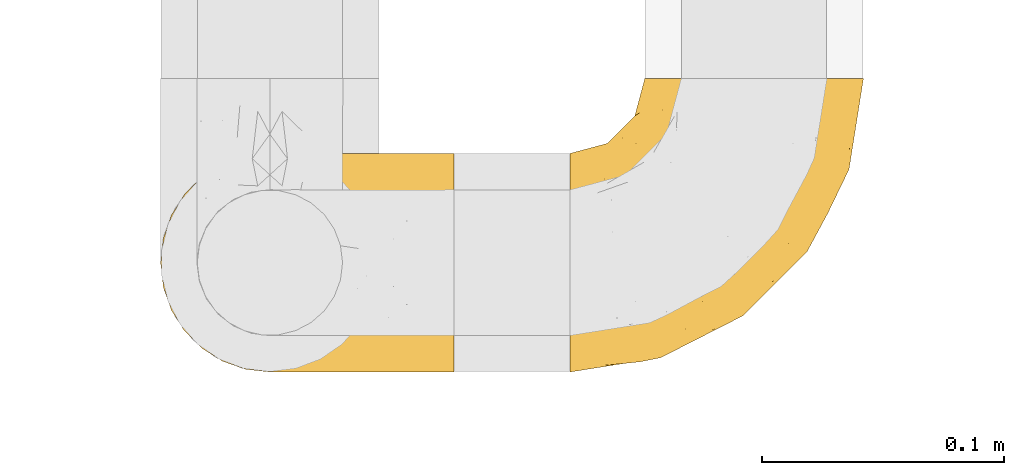
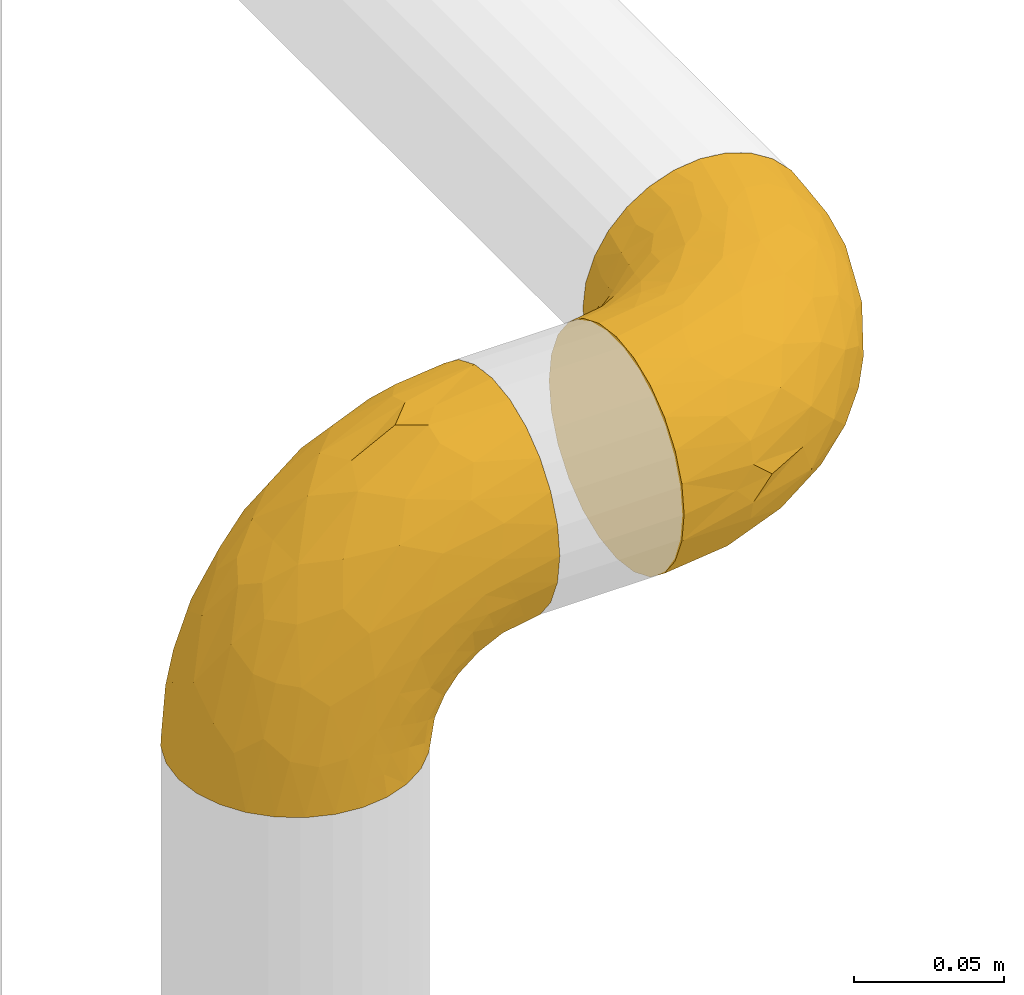
# One storey, part 107 of 827: 2 coverings.
"""IFC2X3 building model written with IfcOpenShell, lengths in millimetres."""

from ifc_helpers import new_model, entity, si_unit, converted_unit, derived_unit, direction, frame, origin, place, context, subcontext, project, spatial, faceted_brep, element, save


model = new_model("IFC2X3")

# Units and contexts
model_context = context("Model", 3, precision=0.01, world=origin(), true_north=direction((6.12303176911189e-17, 1.0)))
body_context = subcontext(model_context, "Body", "Model", "MODEL_VIEW")
ifc_project = project(units=[si_unit("LENGTHUNIT", "METRE", prefix="MILLI"), si_unit("AREAUNIT", "SQUARE_METRE"), si_unit("VOLUMEUNIT", "CUBIC_METRE"), converted_unit("PLANEANGLEUNIT", "DEGREE", entity("IfcRatioMeasure", 0.0174532925199433), si_unit("PLANEANGLEUNIT", "RADIAN"), dimensions=[0, 0, 0, 0, 0, 0, 0]), si_unit("MASSUNIT", "GRAM", prefix="KILO"), derived_unit("MASSDENSITYUNIT", [(si_unit("MASSUNIT", "GRAM", prefix="KILO"), 1), (si_unit("LENGTHUNIT", "METRE"), -3)]), derived_unit("MOMENTOFINERTIAUNIT", [(si_unit("LENGTHUNIT", "METRE"), 4)]), si_unit("TIMEUNIT", "SECOND"), si_unit("FREQUENCYUNIT", "HERTZ"), si_unit("THERMODYNAMICTEMPERATUREUNIT", "DEGREE_CELSIUS"), derived_unit("THERMALTRANSMITTANCEUNIT", [(si_unit("MASSUNIT", "GRAM", prefix="KILO"), 1), (si_unit("THERMODYNAMICTEMPERATUREUNIT", "KELVIN"), -1), (si_unit("TIMEUNIT", "SECOND"), -3)]), derived_unit("VOLUMETRICFLOWRATEUNIT", [(si_unit("LENGTHUNIT", "METRE"), 3), (si_unit("TIMEUNIT", "SECOND"), -1)]), derived_unit("MASSFLOWRATEUNIT", [(si_unit("MASSUNIT", "GRAM", prefix="KILO"), 1), (si_unit("TIMEUNIT", "SECOND"), -1)]), derived_unit("ROTATIONALFREQUENCYUNIT", [(si_unit("TIMEUNIT", "SECOND"), -1)]), si_unit("ELECTRICCURRENTUNIT", "AMPERE"), si_unit("ELECTRICVOLTAGEUNIT", "VOLT"), si_unit("POWERUNIT", "WATT"), si_unit("FORCEUNIT", "NEWTON", prefix="KILO"), si_unit("ILLUMINANCEUNIT", "LUX"), si_unit("LUMINOUSFLUXUNIT", "LUMEN"), si_unit("LUMINOUSINTENSITYUNIT", "CANDELA"), derived_unit("USERDEFINED", [(si_unit("MASSUNIT", "GRAM", prefix="KILO"), -1), (si_unit("LENGTHUNIT", "METRE"), -2), (si_unit("TIMEUNIT", "SECOND"), 3), (si_unit("LUMINOUSFLUXUNIT", "LUMEN"), 1)]), derived_unit("LINEARVELOCITYUNIT", [(si_unit("LENGTHUNIT", "METRE"), 1), (si_unit("TIMEUNIT", "SECOND"), -1)]), si_unit("PRESSUREUNIT", "PASCAL"), derived_unit("USERDEFINED", [(si_unit("LENGTHUNIT", "METRE"), -2), (si_unit("MASSUNIT", "GRAM", prefix="KILO"), 1), (si_unit("TIMEUNIT", "SECOND"), -2)]), derived_unit("LINEARFORCEUNIT", [(si_unit("MASSUNIT", "GRAM", prefix="KILO"), 1), (si_unit("LENGTHUNIT", "METRE"), 1), (si_unit("TIMEUNIT", "SECOND"), -2), (si_unit("LENGTHUNIT", "METRE"), -1)]), derived_unit("PLANARFORCEUNIT", [(si_unit("MASSUNIT", "GRAM", prefix="KILO"), 1), (si_unit("LENGTHUNIT", "METRE"), 1), (si_unit("TIMEUNIT", "SECOND"), -2), (si_unit("LENGTHUNIT", "METRE"), -2)])], contexts=[model_context])

# Site, building, storey
site_placement = place(None, origin())
site = spatial("IfcSite", under=ifc_project, at=site_placement, CompositionType="ELEMENT")
building_placement = place(site_placement, origin())
building = spatial("IfcBuilding", under=site, at=building_placement, CompositionType="ELEMENT")
storey_placement = place(building_placement, frame((0.0, 0.0, 28200.0)))
storey = spatial("IfcBuildingStorey", under=building, at=storey_placement, Name="08", CompositionType="ELEMENT", Elevation=28200.0)

# Coverings
covering_1_placement = place(storey_placement, frame((21222.65, 10451.58, 2353.25)))
element("IfcCovering", 1, at=covering_1_placement, inside=storey, Name=":ADSK_", ObjectType=":ADSK_", PredefinedType="INSULATION", context=body_context, shape_type="Brep", body=[
    faceted_brep([(87.65, 122.75, 90.76), (97.19, 122.75, 87.42), (105.75, 122.75, 82.04), (112.9, 122.75, 74.89), (118.28, 122.75, 66.33), (121.61, 122.75, 56.79), (122.75, 122.75, 46.75), (121.61, 122.75, 36.69), (118.27, 122.75, 27.15), (112.89, 122.75, 18.59), (105.74, 122.75, 11.44), (97.18, 122.75, 6.06), (87.64, 122.75, 2.73), (77.6, 122.75, 1.6), (67.54, 122.75, 2.73), (58.0, 122.75, 6.07), (49.44, 122.75, 11.45), (42.29, 122.75, 18.6), (36.91, 122.75, 27.16), (33.58, 122.75, 36.7), (32.45, 122.75, 46.75), (33.58, 122.75, 56.8), (36.92, 122.75, 66.34), (42.3, 122.75, 74.9), (49.45, 122.75, 82.05), (58.01, 122.75, 87.43), (67.55, 122.75, 90.76), (77.6, 122.75, 91.9), (1.6, 90.36, 35.06), (1.6, 85.85, 24.17), (1.6, 78.67, 14.82), (1.6, 69.32, 7.64), (1.6, 58.43, 3.13), (1.6, 46.75, 1.6), (1.6, 35.06, 3.13), (1.6, 24.17, 7.64), (1.6, 14.82, 14.82), (1.6, 7.64, 24.17), (1.6, 3.13, 35.06), (1.6, 1.6, 46.75), (1.6, 3.13, 58.43), (1.6, 7.64, 69.32), (1.6, 14.82, 78.67), (1.6, 24.17, 85.85), (1.6, 35.06, 90.36), (1.6, 46.75, 91.9), (1.6, 58.43, 90.36), (1.6, 69.32, 85.85), (1.6, 78.67, 78.67), (1.6, 85.85, 69.32), (1.6, 90.36, 58.43), (1.6, 91.9, 46.75), (99.61, 51.54, 46.75), (95.26, 47.17, 55.2), (86.21, 38.13, 46.75), (39.03, 7.52, 46.75), (30.75, 5.85, 54.53), (23.8, 5.11, 46.75), (60.8, 19.2, 59.63), (85.37, 38.98, 62.07), (73.64, 35.02, 71.86), (31.01, 8.21, 62.65), (49.14, 19.28, 71.33), (23.88, 12.19, 72.93), (82.74, 101.39, 91.2), (43.48, 34.43, 86.31), (29.47, 20.95, 80.89), (56.38, 30.74, 79.49), (72.18, 72.93, 90.68), (72.24, 56.64, 86.84), (87.6, 80.81, 87.38), (107.24, 93.43, 76.87), (101.1, 100.76, 83.73), (95.16, 74.27, 81.03), (71.81, 93.66, 91.9), (63.57, 81.33, 91.9), (55.34, 69.01, 91.9), (23.66, 40.87, 91.03), (20.55, 29.38, 87.58), (107.97, 67.05, 56.52), (116.82, 85.31, 46.75), (117.03, 93.68, 60.4), (30.68, 52.53, 91.9), (21.51, 50.71, 91.9), (12.33, 48.88, 91.9), (106.17, 72.77, 67.87), (52.37, 51.21, 90.35), (114.51, 101.18, 69.57), (119.23, 100.54, 46.75), (78.37, 48.74, 79.91), (75.46, 112.01, 91.9), (73.63, 102.83, 91.9), (101.51, 73.88, 74.99), (72.81, 24.73, 46.75), (43.01, 60.77, 91.9), (92.6, 103.08, 88.53), (91.86, 54.8, 72.65), (55.92, 16.13, 46.75), (99.01, 55.92, 62.97), (108.21, 68.42, 46.75), (32.05, 104.98, 66.2), (30.22, 108.58, 56.6), (23.37, 98.21, 59.89), (28.43, 61.56, 90.95), (16.44, 60.69, 90.22), (37.1, 100.0, 76.64), (28.88, 95.88, 71.58), (33.93, 90.81, 79.99), (50.17, 84.88, 89.54), (40.57, 73.29, 89.97), (47.62, 113.4, 81.32), (39.9, 109.8, 74.56), (47.92, 102.13, 84.15), (34.27, 67.29, 90.37), (24.65, 70.34, 87.82), (62.6, 95.15, 90.98), (66.18, 105.49, 90.96), (11.74, 71.5, 85.14), (13.89, 92.87, 58.11), (17.02, 96.03, 46.75), (15.86, 81.34, 78.39), (57.71, 107.44, 88.22), (9.11, 88.36, 66.06), (18.55, 90.43, 68.6), (34.74, 114.37, 63.78), (54.95, 98.41, 88.42), (57.35, 88.73, 90.61), (22.03, 76.89, 83.8), (24.8, 86.08, 77.98), (69.07, 112.64, 91.22), (42.31, 94.21, 83.46), (29.63, 112.22, 46.75), (28.31, 107.32, 46.75), (30.23, 79.95, 84.66), (40.13, 84.51, 86.33), (22.67, 101.67, 46.75), (12.12, 94.71, 46.75), (15.86, 81.34, 15.1), (22.03, 76.89, 9.69), (24.8, 86.08, 15.52), (30.23, 79.96, 8.83), (13.88, 92.87, 35.39), (47.61, 113.41, 12.18), (73.63, 102.83, 1.6), (66.17, 105.5, 2.53), (69.07, 112.64, 2.27), (30.22, 108.58, 36.9), (32.04, 104.98, 27.31), (23.36, 98.2, 33.62), (54.93, 98.4, 5.07), (47.91, 102.13, 9.36), (57.69, 107.44, 5.27), (9.1, 88.36, 27.43), (21.51, 50.71, 1.6), (12.33, 48.88, 1.6), (42.29, 94.22, 10.05), (37.09, 100.01, 16.87), (11.74, 71.5, 8.35), (16.44, 60.69, 3.27), (30.68, 52.53, 1.6), (28.86, 95.89, 21.94), (34.74, 114.37, 29.72), (63.57, 81.33, 1.6), (55.34, 69.01, 1.6), (50.17, 84.88, 3.96), (75.46, 112.01, 1.6), (39.89, 109.8, 18.95), (28.43, 61.56, 2.54), (34.27, 67.29, 3.12), (43.01, 60.77, 1.6), (62.59, 95.14, 2.51), (40.57, 73.29, 3.52), (40.13, 84.53, 7.17), (71.81, 93.66, 1.6), (33.92, 90.82, 13.52), (57.34, 88.73, 2.88), (24.65, 70.34, 5.67), (18.54, 90.43, 24.89), (29.47, 20.95, 12.6), (43.48, 34.43, 7.18), (56.4, 30.74, 14.0), (49.17, 19.29, 22.16), (73.69, 35.07, 21.61), (52.37, 51.21, 3.14), (72.26, 56.67, 6.65), (91.88, 54.85, 20.82), (85.36, 38.98, 31.41), (20.55, 29.38, 5.91), (23.66, 40.87, 2.46), (60.8, 19.2, 33.87), (31.02, 8.21, 30.84), (30.75, 5.85, 38.96), (23.9, 12.19, 20.56), (72.17, 72.93, 2.81), (87.59, 80.83, 6.1), (82.74, 101.39, 2.29), (117.03, 93.69, 33.08), (107.23, 93.43, 16.61), (107.97, 67.04, 36.96), (101.08, 100.76, 9.75), (106.17, 72.78, 25.61), (99.01, 55.93, 30.5), (114.5, 101.18, 23.91), (95.15, 74.27, 12.45), (101.5, 73.89, 18.49), (92.59, 103.09, 4.96), (78.38, 48.78, 13.56), (95.27, 47.19, 38.28)], [[[0, 1, 2, 3, 4, 5, 6, 7, 8, 9, 10, 11, 12, 13, 14, 15, 16, 17, 18, 19, 20, 21, 22, 23, 24, 25, 26, 27]], [[28, 29, 30, 31, 32, 33, 34, 35, 36, 37, 38, 39, 40, 41, 42, 43, 44, 45, 46, 47, 48, 49, 50, 51]], [[52, 53, 54]], [[55, 56, 57]], [[58, 59, 60]], [[61, 62, 63]], [[27, 64, 0]], [[65, 66, 67]], [[41, 40, 61]], [[68, 69, 70]], [[66, 43, 42]], [[63, 42, 41]], [[71, 72, 73]], [[72, 2, 1]], [[68, 74, 75, 76]], [[45, 44, 77]], [[43, 78, 44]], [[79, 80, 81]], [[77, 82, 83, 84, 45]], [[79, 81, 85]], [[71, 2, 72]], [[65, 86, 77]], [[4, 81, 5]], [[66, 65, 78]], [[4, 3, 87]], [[81, 88, 5]], [[63, 66, 42]], [[68, 70, 64]], [[67, 60, 89]], [[71, 3, 2]], [[64, 27, 90, 91, 74]], [[92, 71, 73]], [[40, 57, 56]], [[59, 93, 54]], [[86, 76, 94, 82]], [[1, 0, 95]], [[58, 62, 61]], [[60, 96, 89]], [[85, 81, 87]], [[56, 97, 58]], [[65, 67, 69]], [[87, 81, 4]], [[67, 89, 69]], [[61, 63, 41]], [[95, 72, 1]], [[73, 72, 70]], [[69, 73, 70]], [[73, 89, 96]], [[3, 71, 87]], [[85, 87, 71]], [[58, 61, 56]], [[59, 58, 93]], [[76, 86, 68]], [[69, 89, 73]], [[68, 86, 69]], [[65, 69, 86]], [[68, 64, 74]], [[95, 64, 70]], [[98, 79, 85]], [[79, 52, 99, 80]], [[66, 62, 67]], [[62, 58, 60]], [[62, 60, 67]], [[59, 98, 96]], [[59, 96, 60]], [[96, 85, 92]], [[88, 81, 80]], [[88, 6, 5]], [[66, 63, 62]], [[64, 95, 0]], [[72, 95, 70]], [[77, 44, 78]], [[86, 82, 77]], [[40, 39, 57]], [[96, 98, 85]], [[40, 56, 61]], [[66, 78, 43]], [[77, 78, 65]], [[79, 98, 53]], [[96, 92, 73]], [[85, 71, 92]], [[97, 56, 55]], [[97, 93, 58]], [[53, 98, 59]], [[54, 53, 59]], [[79, 53, 52]], [[100, 101, 102]], [[46, 45, 84, 83]], [[103, 104, 82]], [[82, 104, 83]], [[105, 106, 107]], [[108, 109, 76]], [[110, 111, 112]], [[103, 113, 114]], [[115, 74, 116]], [[48, 47, 117]], [[118, 102, 119]], [[49, 48, 120]], [[74, 91, 116]], [[116, 121, 115]], [[49, 122, 50]], [[123, 106, 102]], [[124, 111, 22]], [[125, 126, 115]], [[23, 22, 111]], [[24, 110, 121]], [[120, 127, 128]], [[90, 26, 129]], [[27, 26, 90]], [[121, 125, 115]], [[24, 121, 25]], [[130, 105, 107]], [[129, 25, 116]], [[21, 20, 131]], [[120, 123, 122]], [[112, 105, 130]], [[50, 118, 51]], [[21, 124, 22]], [[101, 131, 132]], [[117, 120, 48]], [[24, 23, 110]], [[127, 114, 133]], [[75, 108, 76]], [[107, 134, 130]], [[133, 114, 113]], [[129, 116, 91]], [[25, 121, 116]], [[121, 112, 125]], [[75, 74, 115]], [[101, 135, 102]], [[131, 101, 21]], [[101, 100, 124]], [[128, 127, 133]], [[119, 136, 51, 118]], [[104, 47, 46]], [[83, 104, 46]], [[117, 104, 114]], [[101, 124, 21]], [[111, 124, 100]], [[102, 118, 123]], [[133, 134, 107]], [[111, 110, 23]], [[114, 104, 103]], [[94, 76, 109]], [[121, 110, 112]], [[122, 118, 50]], [[134, 109, 108]], [[133, 107, 128]], [[112, 108, 125]], [[126, 125, 108]], [[108, 75, 126]], [[75, 115, 126]], [[109, 134, 133]], [[130, 108, 112]], [[108, 130, 134]], [[105, 112, 111]], [[111, 100, 105]], [[106, 105, 100]], [[102, 106, 100]], [[128, 106, 123]], [[90, 129, 91]], [[25, 129, 26]], [[104, 117, 47]], [[117, 114, 127]], [[82, 94, 103]], [[113, 94, 109]], [[94, 113, 103]], [[133, 113, 109]], [[106, 128, 107]], [[123, 120, 128]], [[120, 122, 49]], [[118, 122, 123]], [[135, 101, 132]], [[135, 119, 102]], [[117, 127, 120]], [[30, 29, 137]], [[138, 139, 140]], [[51, 136, 119, 141]], [[142, 17, 16]], [[143, 144, 145]], [[146, 147, 148]], [[149, 150, 151]], [[152, 29, 28]], [[33, 32, 153, 154]], [[150, 155, 156]], [[157, 31, 30]], [[153, 158, 159]], [[29, 152, 137]], [[148, 141, 119]], [[156, 160, 147]], [[148, 135, 146]], [[137, 138, 157]], [[19, 161, 146]], [[162, 163, 164]], [[14, 13, 165]], [[153, 32, 158]], [[147, 161, 166]], [[18, 17, 166]], [[167, 168, 169]], [[166, 150, 156]], [[151, 150, 142]], [[151, 170, 149]], [[151, 16, 15]], [[171, 140, 172]], [[165, 143, 145]], [[173, 170, 144]], [[142, 166, 17]], [[19, 131, 20]], [[144, 170, 151]], [[18, 161, 19]], [[173, 144, 143]], [[140, 139, 174]], [[171, 164, 163]], [[164, 172, 155]], [[151, 15, 144]], [[145, 15, 14]], [[173, 162, 170]], [[149, 175, 164]], [[19, 146, 131]], [[132, 131, 146]], [[160, 148, 147]], [[159, 158, 167]], [[135, 132, 146]], [[158, 32, 31]], [[157, 158, 31]], [[167, 158, 176]], [[166, 161, 18]], [[146, 161, 147]], [[148, 177, 141]], [[171, 168, 140]], [[171, 163, 169]], [[151, 142, 16]], [[166, 142, 150]], [[152, 141, 177]], [[51, 141, 28]], [[138, 140, 176]], [[172, 140, 174]], [[175, 149, 170]], [[164, 150, 149]], [[170, 162, 175]], [[162, 164, 175]], [[155, 172, 174]], [[171, 172, 164]], [[155, 174, 156]], [[164, 155, 150]], [[160, 156, 174]], [[147, 166, 156]], [[139, 160, 174]], [[148, 160, 177]], [[15, 145, 144]], [[165, 145, 14]], [[137, 157, 30]], [[158, 157, 176]], [[168, 167, 176]], [[169, 159, 167]], [[140, 168, 176]], [[169, 168, 171]], [[137, 177, 139]], [[160, 139, 177]], [[141, 152, 28]], [[137, 152, 177]], [[148, 119, 135]], [[157, 138, 176]], [[139, 138, 137]], [[178, 179, 180]], [[181, 180, 182]], [[179, 183, 184]], [[185, 186, 182]], [[187, 188, 179]], [[188, 33, 154, 153, 159]], [[181, 189, 190]], [[35, 34, 187]], [[191, 38, 190]], [[192, 178, 181]], [[179, 184, 180]], [[192, 190, 37]], [[37, 190, 38]], [[36, 35, 178]], [[54, 93, 186]], [[35, 187, 178]], [[193, 194, 184]], [[195, 173, 143, 165, 13]], [[195, 193, 173]], [[193, 163, 162, 173]], [[13, 12, 195]], [[8, 7, 196]], [[9, 197, 10]], [[198, 80, 99, 52]], [[196, 7, 88]], [[197, 199, 10]], [[182, 189, 181]], [[200, 198, 201]], [[200, 196, 198]], [[9, 8, 202]], [[194, 199, 203]], [[192, 37, 36]], [[80, 196, 88]], [[183, 159, 169, 163]], [[188, 34, 33]], [[202, 200, 197]], [[185, 203, 204]], [[202, 8, 196]], [[10, 199, 11]], [[12, 11, 205]], [[38, 191, 57]], [[189, 97, 191]], [[203, 199, 197]], [[205, 199, 194]], [[204, 203, 197]], [[184, 203, 206]], [[200, 202, 196]], [[197, 9, 202]], [[207, 54, 186]], [[97, 55, 191]], [[194, 203, 184]], [[183, 163, 193]], [[184, 206, 180]], [[183, 193, 184]], [[205, 195, 12]], [[193, 195, 194]], [[80, 198, 196]], [[207, 186, 201]], [[182, 180, 206]], [[181, 178, 180]], [[185, 182, 206]], [[182, 186, 189]], [[203, 185, 206]], [[185, 200, 201]], [[7, 6, 88]], [[178, 192, 36]], [[190, 192, 181]], [[199, 205, 11]], [[195, 205, 194]], [[159, 183, 188]], [[179, 188, 183]], [[57, 191, 55]], [[57, 39, 38]], [[189, 191, 190]], [[188, 187, 34]], [[178, 187, 179]], [[186, 93, 189]], [[197, 200, 204]], [[185, 204, 200]], [[189, 93, 97]], [[207, 198, 52]], [[185, 201, 186]], [[198, 207, 201]], [[54, 207, 52]]]),
])
covering_2_placement = place(storey_placement, frame((21053.55, 10451.58, 2322.4)))
element("IfcCovering", 2, at=covering_2_placement, inside=storey, Name=":ADSK_", ObjectType=":ADSK_", PredefinedType="INSULATION", context=body_context, shape_type="Brep", body=[
    faceted_brep([(36.69, 2.73, 1.6), (27.15, 6.07, 1.6), (18.59, 11.45, 1.6), (11.44, 18.6, 1.6), (6.06, 27.16, 1.6), (2.73, 36.7, 1.6), (1.6, 46.75, 1.6), (2.73, 56.8, 1.6), (6.07, 66.34, 1.6), (11.45, 74.9, 1.6), (18.6, 82.05, 1.6), (27.16, 87.43, 1.6), (36.7, 90.76, 1.6), (46.75, 91.9, 1.6), (56.8, 90.76, 1.6), (66.34, 87.42, 1.6), (74.9, 82.04, 1.6), (82.05, 74.89, 1.6), (87.43, 66.33, 1.6), (90.76, 56.79, 1.6), (91.9, 46.75, 1.6), (90.76, 36.69, 1.6), (87.42, 27.15, 1.6), (82.04, 18.59, 1.6), (74.89, 11.44, 1.6), (66.33, 6.06, 1.6), (56.79, 2.73, 1.6), (46.75, 1.6, 1.6), (122.75, 58.43, 33.98), (122.75, 69.32, 38.49), (122.75, 78.67, 45.67), (122.75, 85.85, 55.02), (122.75, 90.36, 65.91), (122.75, 91.9, 77.6), (122.75, 90.36, 89.28), (122.75, 85.85, 100.17), (122.75, 78.67, 109.52), (122.75, 69.32, 116.7), (122.75, 58.43, 121.21), (122.75, 46.75, 122.75), (122.75, 35.06, 121.21), (122.75, 24.17, 116.7), (122.75, 14.82, 109.52), (122.75, 7.64, 100.17), (122.75, 3.13, 89.28), (122.75, 1.6, 77.6), (122.75, 3.13, 65.91), (122.75, 7.64, 55.02), (122.75, 14.82, 45.67), (122.75, 24.17, 38.49), (122.75, 35.06, 33.98), (122.75, 46.75, 32.45), (24.73, 46.75, 72.81), (29.08, 38.29, 77.17), (38.13, 46.75, 86.21), (85.31, 46.75, 116.82), (93.59, 38.96, 118.49), (100.54, 46.75, 119.23), (63.54, 33.86, 105.14), (38.98, 31.42, 85.37), (50.71, 21.63, 89.33), (93.33, 30.84, 116.14), (75.2, 22.16, 105.06), (100.46, 20.56, 112.15), (41.6, 2.29, 22.95), (80.86, 7.18, 89.91), (94.87, 12.6, 103.39), (67.96, 14.0, 93.6), (52.16, 2.81, 51.41), (52.1, 6.65, 67.71), (36.74, 6.11, 43.53), (17.11, 16.62, 30.91), (23.24, 9.76, 23.58), (29.18, 12.46, 50.07), (52.53, 1.6, 30.68), (60.77, 1.6, 43.01), (69.01, 1.6, 55.34), (100.68, 2.46, 83.48), (103.79, 5.91, 94.96), (16.37, 36.97, 57.29), (7.52, 46.75, 39.03), (7.31, 33.09, 30.66), (93.66, 1.6, 71.81), (102.83, 1.6, 73.63), (112.01, 1.6, 75.46), (18.17, 25.62, 51.57), (71.97, 3.14, 73.13), (9.83, 23.92, 23.16), (5.11, 46.75, 23.8), (45.97, 13.58, 75.6), (48.88, 1.6, 12.33), (50.71, 1.6, 21.51), (22.83, 18.5, 50.46), (51.54, 46.75, 99.61), (81.33, 1.6, 63.57), (31.74, 4.96, 21.26), (32.48, 20.84, 69.54), (68.42, 46.75, 108.21), (25.33, 30.52, 68.42), (16.13, 46.75, 55.92), (92.29, 27.29, 19.36), (94.12, 36.89, 15.76), (100.97, 33.6, 26.13), (95.91, 2.54, 62.78), (107.9, 3.27, 63.65), (87.24, 16.85, 24.34), (95.46, 21.91, 28.46), (90.41, 13.5, 33.53), (74.17, 3.96, 39.46), (83.77, 3.52, 51.05), (76.72, 12.17, 10.94), (84.44, 18.93, 14.55), (76.42, 9.34, 22.21), (90.07, 3.12, 57.05), (99.69, 5.67, 54.0), (61.74, 2.51, 29.19), (58.16, 2.53, 18.85), (112.6, 8.35, 52.84), (110.45, 35.39, 31.47), (107.32, 46.75, 28.31), (108.48, 15.1, 43.0), (66.63, 5.27, 16.9), (115.23, 27.43, 35.98), (105.79, 24.89, 33.91), (89.6, 29.71, 9.97), (69.39, 5.07, 25.93), (66.99, 2.88, 35.61), (102.31, 9.69, 47.45), (99.54, 15.51, 38.26), (55.27, 2.27, 11.7), (82.03, 10.03, 30.13), (94.71, 46.75, 12.12), (96.03, 46.75, 17.02), (94.11, 8.83, 44.39), (84.21, 7.16, 39.83), (101.67, 46.75, 22.67), (112.22, 46.75, 29.63), (108.48, 78.39, 43.0), (102.31, 83.8, 47.45), (99.54, 77.97, 38.26), (94.11, 84.66, 44.38), (110.46, 58.1, 31.47), (76.74, 81.31, 10.93), (50.71, 91.9, 21.51), (58.17, 90.96, 18.84), (55.27, 91.22, 11.7), (94.12, 56.59, 15.76), (92.3, 66.18, 19.36), (100.98, 59.87, 26.14), (69.41, 88.42, 25.94), (76.44, 84.13, 22.21), (66.65, 88.22, 16.9), (115.24, 66.06, 35.98), (102.83, 91.9, 73.63), (112.01, 91.9, 75.46), (82.05, 83.44, 30.12), (87.25, 76.62, 24.33), (112.6, 85.14, 52.84), (107.9, 90.22, 63.65), (93.66, 91.9, 71.81), (95.48, 71.55, 28.45), (89.6, 63.77, 9.97), (60.77, 91.9, 43.01), (69.01, 91.9, 55.34), (74.17, 89.53, 39.46), (48.88, 91.9, 12.33), (84.45, 74.55, 14.54), (95.91, 90.95, 62.78), (90.07, 90.37, 57.05), (81.33, 91.9, 63.57), (61.75, 90.98, 29.2), (83.77, 89.97, 51.05), (84.21, 86.32, 39.81), (52.53, 91.9, 30.68), (90.42, 79.97, 33.52), (67.0, 90.61, 35.61), (99.69, 87.82, 54.0), (105.8, 68.6, 33.91), (94.87, 80.89, 103.39), (80.86, 86.31, 89.91), (67.95, 79.49, 93.6), (75.17, 71.33, 105.05), (50.65, 71.88, 89.27), (71.97, 90.35, 73.13), (52.08, 86.85, 67.67), (32.46, 72.67, 69.49), (38.98, 62.08, 85.36), (103.79, 87.58, 94.96), (100.68, 91.03, 83.48), (63.54, 59.62, 105.14), (93.32, 62.65, 116.13), (93.59, 54.53, 118.49), (100.44, 72.93, 112.15), (52.17, 90.68, 51.41), (36.75, 87.39, 43.51), (41.61, 91.2, 22.95), (7.31, 60.41, 30.66), (17.12, 76.88, 30.91), (16.37, 56.53, 57.3), (23.26, 83.74, 23.58), (18.17, 67.88, 51.56), (25.33, 62.99, 68.41), (9.84, 69.58, 23.16), (29.19, 81.04, 50.07), (22.84, 75.0, 50.45), (31.75, 88.53, 21.25), (45.96, 79.93, 75.56), (29.07, 55.21, 77.16)], [[[0, 1, 2, 3, 4, 5, 6, 7, 8, 9, 10, 11, 12, 13, 14, 15, 16, 17, 18, 19, 20, 21, 22, 23, 24, 25, 26, 27]], [[28, 29, 30, 31, 32, 33, 34, 35, 36, 37, 38, 39, 40, 41, 42, 43, 44, 45, 46, 47, 48, 49, 50, 51]], [[52, 53, 54]], [[55, 56, 57]], [[58, 59, 60]], [[61, 62, 63]], [[27, 64, 0]], [[65, 66, 67]], [[41, 40, 61]], [[68, 69, 70]], [[66, 43, 42]], [[63, 42, 41]], [[71, 72, 73]], [[72, 2, 1]], [[68, 74, 75, 76]], [[45, 44, 77]], [[43, 78, 44]], [[79, 80, 81]], [[77, 82, 83, 84, 45]], [[79, 81, 85]], [[71, 2, 72]], [[65, 86, 77]], [[4, 81, 5]], [[66, 65, 78]], [[4, 3, 87]], [[81, 88, 5]], [[63, 66, 42]], [[68, 70, 64]], [[67, 60, 89]], [[71, 3, 2]], [[64, 27, 90, 91, 74]], [[92, 71, 73]], [[40, 57, 56]], [[59, 93, 54]], [[86, 76, 94, 82]], [[1, 0, 95]], [[58, 62, 61]], [[60, 96, 89]], [[85, 81, 87]], [[56, 97, 58]], [[65, 67, 69]], [[87, 81, 4]], [[67, 89, 69]], [[61, 63, 41]], [[95, 72, 1]], [[73, 72, 70]], [[69, 73, 70]], [[73, 89, 96]], [[3, 71, 87]], [[85, 87, 71]], [[58, 61, 56]], [[59, 58, 93]], [[76, 86, 68]], [[69, 89, 73]], [[68, 86, 69]], [[65, 69, 86]], [[68, 64, 74]], [[95, 64, 70]], [[98, 79, 85]], [[79, 52, 99, 80]], [[66, 62, 67]], [[62, 58, 60]], [[62, 60, 67]], [[59, 98, 96]], [[59, 96, 60]], [[96, 85, 92]], [[88, 81, 80]], [[88, 6, 5]], [[66, 63, 62]], [[64, 95, 0]], [[72, 95, 70]], [[77, 44, 78]], [[86, 82, 77]], [[40, 39, 57]], [[96, 98, 85]], [[40, 56, 61]], [[66, 78, 43]], [[77, 78, 65]], [[79, 98, 53]], [[96, 92, 73]], [[85, 71, 92]], [[97, 56, 55]], [[97, 93, 58]], [[53, 98, 59]], [[54, 53, 59]], [[79, 53, 52]], [[100, 101, 102]], [[46, 45, 84, 83]], [[103, 104, 82]], [[82, 104, 83]], [[105, 106, 107]], [[108, 109, 76]], [[110, 111, 112]], [[103, 113, 114]], [[115, 74, 116]], [[48, 47, 117]], [[118, 102, 119]], [[49, 48, 120]], [[74, 91, 116]], [[116, 121, 115]], [[49, 122, 50]], [[123, 106, 102]], [[124, 111, 22]], [[125, 126, 115]], [[23, 22, 111]], [[24, 110, 121]], [[120, 127, 128]], [[90, 26, 129]], [[27, 26, 90]], [[121, 125, 115]], [[24, 121, 25]], [[130, 105, 107]], [[129, 25, 116]], [[21, 20, 131]], [[120, 123, 122]], [[112, 105, 130]], [[50, 118, 51]], [[21, 124, 22]], [[101, 131, 132]], [[117, 120, 48]], [[24, 23, 110]], [[127, 114, 133]], [[75, 108, 76]], [[107, 134, 130]], [[133, 114, 113]], [[129, 116, 91]], [[25, 121, 116]], [[121, 112, 125]], [[75, 74, 115]], [[101, 135, 102]], [[131, 101, 21]], [[101, 100, 124]], [[128, 127, 133]], [[119, 136, 51, 118]], [[104, 47, 46]], [[83, 104, 46]], [[117, 104, 114]], [[101, 124, 21]], [[111, 124, 100]], [[102, 118, 123]], [[133, 134, 107]], [[111, 110, 23]], [[114, 104, 103]], [[94, 76, 109]], [[121, 110, 112]], [[122, 118, 50]], [[134, 109, 108]], [[133, 107, 128]], [[112, 108, 125]], [[126, 125, 108]], [[108, 75, 126]], [[75, 115, 126]], [[109, 134, 133]], [[130, 108, 112]], [[108, 130, 134]], [[105, 112, 111]], [[111, 100, 105]], [[106, 105, 100]], [[102, 106, 100]], [[128, 106, 123]], [[90, 129, 91]], [[25, 129, 26]], [[104, 117, 47]], [[117, 114, 127]], [[82, 94, 103]], [[113, 94, 109]], [[94, 113, 103]], [[133, 113, 109]], [[106, 128, 107]], [[123, 120, 128]], [[120, 122, 49]], [[118, 122, 123]], [[135, 101, 132]], [[135, 119, 102]], [[117, 127, 120]], [[30, 29, 137]], [[138, 139, 140]], [[51, 136, 119, 141]], [[142, 17, 16]], [[143, 144, 145]], [[146, 147, 148]], [[149, 150, 151]], [[152, 29, 28]], [[33, 32, 153, 154]], [[150, 155, 156]], [[157, 31, 30]], [[153, 158, 159]], [[29, 152, 137]], [[148, 141, 119]], [[156, 160, 147]], [[148, 135, 146]], [[137, 138, 157]], [[19, 161, 146]], [[162, 163, 164]], [[14, 13, 165]], [[153, 32, 158]], [[147, 161, 166]], [[18, 17, 166]], [[167, 168, 169]], [[166, 150, 156]], [[151, 150, 142]], [[151, 170, 149]], [[151, 16, 15]], [[171, 140, 172]], [[165, 143, 145]], [[173, 170, 144]], [[142, 166, 17]], [[19, 131, 20]], [[144, 170, 151]], [[18, 161, 19]], [[173, 144, 143]], [[140, 139, 174]], [[171, 164, 163]], [[164, 172, 155]], [[151, 15, 144]], [[145, 15, 14]], [[173, 162, 170]], [[149, 175, 164]], [[19, 146, 131]], [[132, 131, 146]], [[160, 148, 147]], [[159, 158, 167]], [[135, 132, 146]], [[158, 32, 31]], [[157, 158, 31]], [[167, 158, 176]], [[166, 161, 18]], [[146, 161, 147]], [[148, 177, 141]], [[171, 168, 140]], [[171, 163, 169]], [[151, 142, 16]], [[166, 142, 150]], [[152, 141, 177]], [[51, 141, 28]], [[138, 140, 176]], [[172, 140, 174]], [[175, 149, 170]], [[164, 150, 149]], [[170, 162, 175]], [[162, 164, 175]], [[155, 172, 174]], [[171, 172, 164]], [[155, 174, 156]], [[164, 155, 150]], [[160, 156, 174]], [[147, 166, 156]], [[139, 160, 174]], [[148, 160, 177]], [[15, 145, 144]], [[165, 145, 14]], [[137, 157, 30]], [[158, 157, 176]], [[168, 167, 176]], [[169, 159, 167]], [[140, 168, 176]], [[169, 168, 171]], [[137, 177, 139]], [[160, 139, 177]], [[141, 152, 28]], [[137, 152, 177]], [[148, 119, 135]], [[157, 138, 176]], [[139, 138, 137]], [[178, 179, 180]], [[181, 180, 182]], [[179, 183, 184]], [[185, 186, 182]], [[187, 188, 179]], [[188, 33, 154, 153, 159]], [[181, 189, 190]], [[35, 34, 187]], [[191, 38, 190]], [[192, 178, 181]], [[179, 184, 180]], [[192, 190, 37]], [[37, 190, 38]], [[36, 35, 178]], [[54, 93, 186]], [[35, 187, 178]], [[193, 194, 184]], [[195, 173, 143, 165, 13]], [[195, 193, 173]], [[193, 163, 162, 173]], [[13, 12, 195]], [[8, 7, 196]], [[9, 197, 10]], [[198, 80, 99, 52]], [[196, 7, 88]], [[197, 199, 10]], [[182, 189, 181]], [[200, 198, 201]], [[200, 196, 198]], [[9, 8, 202]], [[194, 199, 203]], [[192, 37, 36]], [[80, 196, 88]], [[183, 159, 169, 163]], [[188, 34, 33]], [[202, 200, 197]], [[185, 203, 204]], [[202, 8, 196]], [[10, 199, 11]], [[12, 11, 205]], [[38, 191, 57]], [[189, 97, 191]], [[203, 199, 197]], [[205, 199, 194]], [[204, 203, 197]], [[184, 203, 206]], [[200, 202, 196]], [[197, 9, 202]], [[207, 54, 186]], [[97, 55, 191]], [[194, 203, 184]], [[183, 163, 193]], [[184, 206, 180]], [[183, 193, 184]], [[205, 195, 12]], [[193, 195, 194]], [[80, 198, 196]], [[207, 186, 201]], [[182, 180, 206]], [[181, 178, 180]], [[185, 182, 206]], [[182, 186, 189]], [[203, 185, 206]], [[185, 200, 201]], [[7, 6, 88]], [[178, 192, 36]], [[190, 192, 181]], [[199, 205, 11]], [[195, 205, 194]], [[159, 183, 188]], [[179, 188, 183]], [[57, 191, 55]], [[57, 39, 38]], [[189, 191, 190]], [[188, 187, 34]], [[178, 187, 179]], [[186, 93, 189]], [[197, 200, 204]], [[185, 204, 200]], [[189, 93, 97]], [[207, 198, 52]], [[185, 201, 186]], [[198, 207, 201]], [[54, 207, 52]]]),
])

save(model, "model.ifc")
